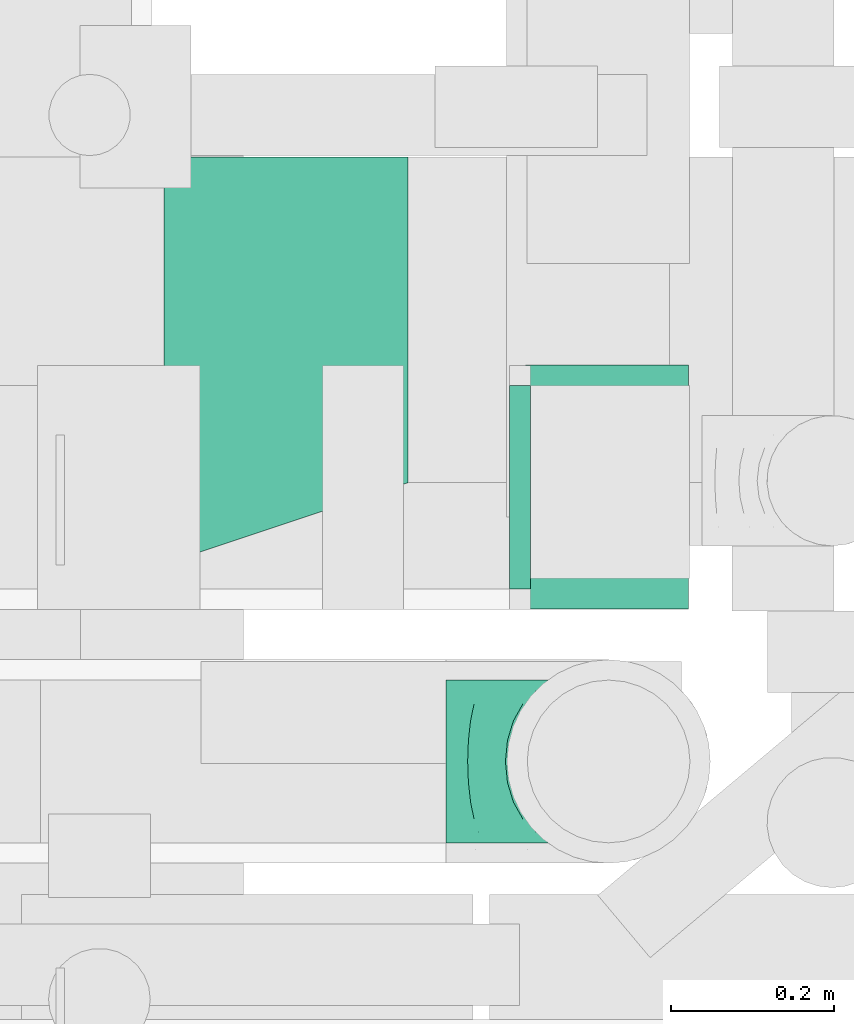
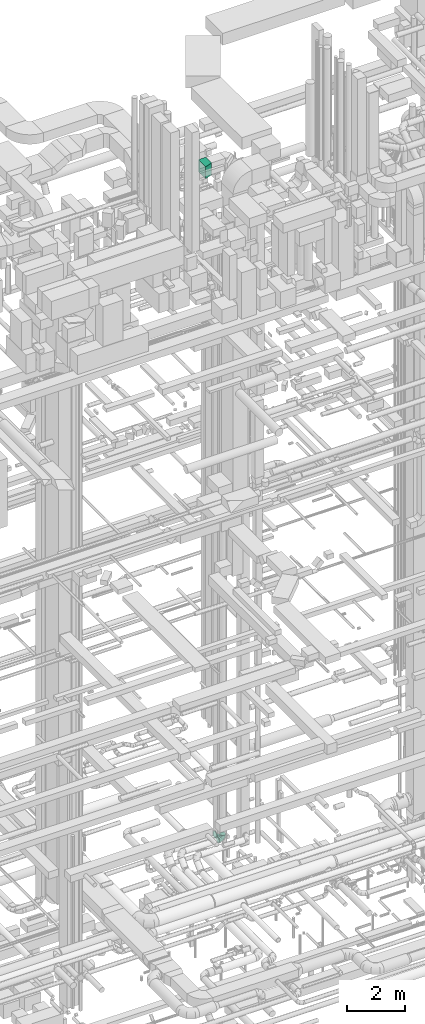
# One storey, part 194 of 337: 4 flow fittings.
"""IFC2X3 building model written with IfcOpenShell, lengths in millimetres."""

import ifcopenshell
import ifcopenshell.guid

model = None  # the IFC model being written
_history = None  # IfcOwnerHistory: only IFC2X3 demands one
_inside = {}  # id of a spatial element -> (the spatial element, [elements in it])
_under = {}  # id of a project, library or spatial element -> (it, [spatial elements below it])
_declared = {}  # id of a project -> (the project, [libraries it declares])
_typed = {}  # id of a type object -> (the type object, [elements of that type])
_made_of = {}  # id of a material, layer set ... -> (it, [elements and type objects made of it])


def new_model(schema):
    """Start an empty IFC model of exactly this schema.

    Asked for "IFC4X3", IfcOpenShell would pick the latest addendum, in which some entities
    have other attributes; the version numbers below select the first issue.
    IFC2X3 requires an IfcOwnerHistory on every rooted entity: one is made here for all.
    """
    global model, _history
    if schema == "IFC4X3":
        model = ifcopenshell.file(schema_version=(4, 3, 0, 0))
    else:
        model = ifcopenshell.file(schema=schema)
    _inside.clear()
    _under.clear()
    _declared.clear()
    _typed.clear()
    _made_of.clear()
    _history = None
    if model.schema == "IFC2X3":
        org = make("IfcOrganization", Name="unknown")
        user = make(
            "IfcPersonAndOrganization",
            ThePerson=make("IfcPerson", FamilyName="unknown"),
            TheOrganization=org,
        )
        app = make(
            "IfcApplication",
            ApplicationDeveloper=org,
            Version="unknown",
            ApplicationFullName="unknown",
            ApplicationIdentifier="unknown",
        )
        _history = make(
            "IfcOwnerHistory",
            OwningUser=user,
            OwningApplication=app,
            ChangeAction="ADDED",
            CreationDate=0,
        )
    return model


def make(cls, **values):
    """One entity of the class cls with the attributes given. An attribute that is None is left unset."""
    return model.create_entity(
        cls, **{name: value for name, value in values.items() if value is not None}
    )


def entity(cls, *values):
    """Any entity or typed value of the class cls, its attributes in the order of the schema. None: left unset."""
    e = model.create_entity(cls)
    for i, value in enumerate(values):
        if value is not None:
            e[i] = value
    return e


def rooted(cls, **values):
    """An entity with a GlobalId (a new one), such as an element, a storey or a relation."""
    return make(cls, GlobalId=ifcopenshell.guid.new(), OwnerHistory=_history, **values)


def si_unit(unit_type, name, prefix=None):
    """IfcSIUnit, for example si_unit("LENGTHUNIT", "METRE", prefix="MILLI")."""
    return make("IfcSIUnit", UnitType=unit_type, Prefix=prefix, Name=name)


def converted_unit(unit_type, name, factor, base, dimensions=None, offset=None):
    """IfcConversionBasedUnit, such as the inch: factor (a typed value) times the base unit."""
    return make(
        "IfcConversionBasedUnit"
        if offset is None
        else "IfcConversionBasedUnitWithOffset",
        ConversionOffset=offset,
        Dimensions=None
        if dimensions is None
        else entity("IfcDimensionalExponents", *dimensions),
        UnitType=unit_type,
        Name=name,
        ConversionFactor=make(
            "IfcMeasureWithUnit", ValueComponent=factor, UnitComponent=base
        ),
    )


def derived_unit(unit_type, elements):
    """IfcDerivedUnit: a product of units, each with its exponent."""
    return make(
        "IfcDerivedUnit",
        Elements=[
            make("IfcDerivedUnitElement", Unit=unit, Exponent=power)
            for unit, power in elements
        ],
        UnitType=unit_type,
    )


def assignment(units):
    """IfcUnitAssignment: the units of a project."""
    return None if units is None else make("IfcUnitAssignment", Units=units)


def point(xyz):
    """IfcCartesianPoint."""
    return None if xyz is None else make("IfcCartesianPoint", Coordinates=xyz)


def direction(xyz):
    """IfcDirection."""
    return None if xyz is None else make("IfcDirection", DirectionRatios=xyz)


def frame(location, z_axis=None, x_axis=None):
    """IfcAxis2Placement3D, a coordinate frame: its origin and axes. An axis left out is left unset."""
    return make(
        "IfcAxis2Placement3D",
        Location=point(location),
        Axis=direction(z_axis),
        RefDirection=direction(x_axis),
    )


def frame_2d(location, x_axis=None):
    """IfcAxis2Placement2D, a coordinate frame in the plane: its origin and x axis."""
    return make(
        "IfcAxis2Placement2D", Location=point(location), RefDirection=direction(x_axis)
    )


def origin():
    """The frame at (0, 0, 0) with its axes left unset."""
    return frame((0.0, 0.0, 0.0))


def origin_2d_with_axis():
    """The frame at (0, 0) in the plane with the x axis (1, 0) written out."""
    return frame_2d((0.0, 0.0), x_axis=(1.0, 0.0))


def place(relative_to, where):
    """IfcLocalPlacement: puts the frame where relative to a parent placement (None: the world)."""
    return make(
        "IfcLocalPlacement", PlacementRelTo=relative_to, RelativePlacement=where
    )


def context(
    kind, dimensions, precision=None, world=None, true_north=None, identifier=None
):
    """IfcGeometricRepresentationContext, for example the 3D "Model" context."""
    return make(
        "IfcGeometricRepresentationContext",
        ContextIdentifier=identifier,
        ContextType=kind,
        CoordinateSpaceDimension=dimensions,
        Precision=precision,
        WorldCoordinateSystem=world,
        TrueNorth=true_north,
    )


def subcontext(parent, identifier, kind, view, scale=None):
    """IfcGeometricRepresentationSubContext, for example "Body" below "Model"."""
    return make(
        "IfcGeometricRepresentationSubContext",
        ContextIdentifier=identifier,
        ContextType=kind,
        ParentContext=parent,
        TargetScale=scale,
        TargetView=view,
    )


def project(units=None, contexts=None):
    """IfcProject with its units and contexts."""
    return rooted(
        "IfcProject",
        Name="project",
        RepresentationContexts=contexts,
        UnitsInContext=assignment(units),
    )


def spatial(cls, under=None, at=None, **own):
    """A site, building, storey or space (cls), placed at a placement, below another one or the project."""
    s = rooted(cls, ObjectPlacement=at, **own)
    if under is not None:
        _under.setdefault(under.id(), (under, []))[1].append(s)
    return s


def polyline(points):
    """IfcPolyline through the points."""
    return make("IfcPolyline", Points=[point(p) for p in points])


def profile(cls, at=None, kind="AREA", **sizes):
    """A parametric profile (cls). Its sizes go by their IFC names, for example OverallWidth=200.0."""
    return make(cls, ProfileType=kind, Position=at, **sizes)


def rectangle(**sizes):
    """IfcRectangleProfileDef."""
    return profile("IfcRectangleProfileDef", **sizes)


def outline(outer, holes=None, kind="AREA"):
    """IfcArbitraryClosedProfileDef: a profile drawn as a closed curve; with holes, ...WithVoids."""
    if holes is None:
        return make("IfcArbitraryClosedProfileDef", ProfileType=kind, OuterCurve=outer)
    return make(
        "IfcArbitraryProfileDefWithVoids",
        ProfileType=kind,
        OuterCurve=outer,
        InnerCurves=holes,
    )


def extrude(swept, where, along, depth):
    """IfcExtrudedAreaSolid: the profile swept, set in the frame where, extruded along a direction by depth."""
    return make(
        "IfcExtrudedAreaSolid",
        SweptArea=swept,
        Position=where,
        ExtrudedDirection=direction(along),
        Depth=depth,
    )


def faces_of(points, faces, orient=None, outer=None):
    """IfcFace entities. A face is a list of loops; a loop is a list of indices into points, from 0.

    orient and outer hold one flag for each loop. By default every Orientation is true, the
    first loop of a face is its IfcFaceOuterBound and the others are IfcFaceBound.
    """
    made = []
    for i, loops in enumerate(faces):
        bounds = []
        for j, loop in enumerate(loops):
            is_outer = j == 0 if outer is None else outer[i][j]
            bounds.append(
                make(
                    "IfcFaceOuterBound" if is_outer else "IfcFaceBound",
                    Bound=make("IfcPolyLoop", Polygon=[points[k] for k in loop]),
                    Orientation=True if orient is None else orient[i][j],
                )
            )
        made.append(make("IfcFace", Bounds=bounds))
    return made


def faceted_brep(points, faces, orient=None, outer=None, voids=None):
    """IfcFacetedBrep: a solid bounded by flat faces; with voids (closed shells), ...WithVoids."""
    shared = [point(p) for p in points]
    hull = make("IfcClosedShell", CfsFaces=faces_of(shared, faces, orient, outer))
    if voids is None:
        return make("IfcFacetedBrep", Outer=hull)
    return make(
        "IfcFacetedBrepWithVoids",
        Outer=hull,
        Voids=[
            make(cls, CfsFaces=faces_of(shared, fs, o, b)) for cls, fs, o, b in voids
        ],
    )


def shape(context_of_items, identifier, shape_type, items):
    """IfcShapeRepresentation: the items that make up one representation, for example the "Body"."""
    return make(
        "IfcShapeRepresentation",
        ContextOfItems=context_of_items,
        RepresentationIdentifier=identifier,
        RepresentationType=shape_type,
        Items=items,
    )


def source(mapping_origin, context_of_items, identifier, shape_type, items):
    """IfcRepresentationMap: a shape defined once, which mapped items show again and again."""
    return make(
        "IfcRepresentationMap",
        MappingOrigin=mapping_origin,
        MappedRepresentation=shape(context_of_items, identifier, shape_type, items),
    )


def transform(
    local_origin,
    x_axis=None,
    y_axis=None,
    z_axis=None,
    scale=None,
    scale2=None,
    scale3=None,
    uniform=True,
):
    """IfcCartesianTransformationOperator3D, or its non-uniform kind. x_axis, y_axis, z_axis: its Axis1, 2, 3."""
    if uniform:
        return make(
            "IfcCartesianTransformationOperator3D",
            Axis1=direction(x_axis),
            Axis2=direction(y_axis),
            LocalOrigin=point(local_origin),
            Scale=scale,
            Axis3=direction(z_axis),
        )
    return make(
        "IfcCartesianTransformationOperator3DnonUniform",
        Axis1=direction(x_axis),
        Axis2=direction(y_axis),
        LocalOrigin=point(local_origin),
        Scale=scale,
        Axis3=direction(z_axis),
        Scale2=scale2,
        Scale3=scale3,
    )


def mapped(mapping_source, mapping_target):
    """IfcMappedItem: shows the shape of a source again, moved by a transform."""
    return make(
        "IfcMappedItem", MappingSource=mapping_source, MappingTarget=mapping_target
    )


def material(Name=None, Category=None):
    """IfcMaterial."""
    return make("IfcMaterial", Name=Name, Category=Category)


def made_of(thing, what):
    """Note that an element or type object is made of a material, layer set ...; save() writes the relation."""
    if what is not None:
        _made_of.setdefault(what.id(), (what, []))[1].append(thing)
    return thing


def type_object(cls, material=None, **own):
    """A type object (cls), such as IfcWallType, which elements share."""
    return made_of(rooted(cls, **own), material)


def type_shapes(of_type, sources):
    """Give a type object the sources (RepresentationMaps) that its elements show as mapped items."""
    of_type.RepresentationMaps = sources


def element(
    cls,
    number,
    at=None,
    inside=None,
    cuts=None,
    type_object=None,
    material=None,
    context=None,
    identifier="Body",
    shape_type=None,
    held_by="IfcProductDefinitionShape",
    body=None,
    shapes=None,
    **own,
):
    """One element of the class cls, such as IfcWall. Its Tag is "e" and its number.

    at: its placement. inside: the storey or other place that contains it. cuts: it is an
    opening in that element (IfcRelVoidsElement). A single representation is given by context,
    identifier, shape_type and body (its items); several are given by shapes. held_by: the class
    of the entity that holds the representations. save() writes the other relations.
    """
    e = rooted(cls, Tag="e%d" % number, ObjectPlacement=at, **own)
    if body is not None:
        shapes = [shape(context, identifier, shape_type, body)]
    if shapes is not None:
        e.Representation = make(held_by, Representations=shapes)
    if inside is not None:
        _inside.setdefault(inside.id(), (inside, []))[1].append(e)
    if cuts is not None:
        rooted(
            "IfcRelVoidsElement", RelatingBuildingElement=cuts, RelatedOpeningElement=e
        )
    if type_object is not None:
        _typed.setdefault(type_object.id(), (type_object, []))[1].append(e)
    return made_of(e, material)


def aggregate(whole, parts):
    """IfcRelAggregates: a whole, such as a stair, and the parts it consists of."""
    return rooted("IfcRelAggregates", RelatingObject=whole, RelatedObjects=parts)


def save(model, path):
    """Write the relations noted so far, then the file.

    IfcRelAggregates (storeys below a building ...), IfcRelContainedInSpatialStructure (elements
    in a storey), IfcRelDefinesByType, IfcRelAssociatesMaterial and IfcRelDeclares: one each for
    every whole, place, type object, material and project.
    """
    for whole, parts in _under.values():
        aggregate(whole, parts)
    for where, things in _inside.values():
        rooted(
            "IfcRelContainedInSpatialStructure",
            RelatedElements=things,
            RelatingStructure=where,
        )
    for kind, things in _typed.values():
        rooted("IfcRelDefinesByType", RelatedObjects=things, RelatingType=kind)
    for what, things in _made_of.values():
        rooted("IfcRelAssociatesMaterial", RelatedObjects=things, RelatingMaterial=what)
    for by, libraries in _declared.values():
        rooted("IfcRelDeclares", RelatingContext=by, RelatedDefinitions=libraries)
    model.write(path)


model = new_model("IFC2X3")

# Units and contexts
model_context = context("Model", 3, precision=0.01, world=origin(), true_north=direction((6.12303176911189e-17, 1.0)))
body_context = subcontext(model_context, "Body", "Model", "MODEL_VIEW")
ifc_project = project(units=[si_unit("LENGTHUNIT", "METRE", prefix="MILLI"), si_unit("AREAUNIT", "SQUARE_METRE"), si_unit("VOLUMEUNIT", "CUBIC_METRE"), converted_unit("PLANEANGLEUNIT", "DEGREE", entity("IfcRatioMeasure", 0.0174532925199433), si_unit("PLANEANGLEUNIT", "RADIAN"), dimensions=[0, 0, 0, 0, 0, 0, 0]), si_unit("MASSUNIT", "GRAM", prefix="KILO"), derived_unit("MASSDENSITYUNIT", [(si_unit("MASSUNIT", "GRAM", prefix="KILO"), 1), (si_unit("LENGTHUNIT", "METRE"), -3)]), derived_unit("MOMENTOFINERTIAUNIT", [(si_unit("LENGTHUNIT", "METRE"), 4)]), si_unit("TIMEUNIT", "SECOND"), si_unit("FREQUENCYUNIT", "HERTZ"), si_unit("THERMODYNAMICTEMPERATUREUNIT", "DEGREE_CELSIUS"), derived_unit("THERMALTRANSMITTANCEUNIT", [(si_unit("MASSUNIT", "GRAM", prefix="KILO"), 1), (si_unit("THERMODYNAMICTEMPERATUREUNIT", "KELVIN"), -1), (si_unit("TIMEUNIT", "SECOND"), -3)]), derived_unit("VOLUMETRICFLOWRATEUNIT", [(si_unit("LENGTHUNIT", "METRE"), 3), (si_unit("TIMEUNIT", "SECOND"), -1)]), derived_unit("MASSFLOWRATEUNIT", [(si_unit("MASSUNIT", "GRAM", prefix="KILO"), 1), (si_unit("TIMEUNIT", "SECOND"), -1)]), derived_unit("ROTATIONALFREQUENCYUNIT", [(si_unit("TIMEUNIT", "SECOND"), -1)]), si_unit("ELECTRICCURRENTUNIT", "AMPERE"), si_unit("ELECTRICVOLTAGEUNIT", "VOLT"), si_unit("POWERUNIT", "WATT"), si_unit("FORCEUNIT", "NEWTON", prefix="KILO"), si_unit("ILLUMINANCEUNIT", "LUX"), si_unit("LUMINOUSFLUXUNIT", "LUMEN"), si_unit("LUMINOUSINTENSITYUNIT", "CANDELA"), derived_unit("USERDEFINED", [(si_unit("MASSUNIT", "GRAM", prefix="KILO"), -1), (si_unit("LENGTHUNIT", "METRE"), -2), (si_unit("TIMEUNIT", "SECOND"), 3), (si_unit("LUMINOUSFLUXUNIT", "LUMEN"), 1)]), derived_unit("LINEARVELOCITYUNIT", [(si_unit("LENGTHUNIT", "METRE"), 1), (si_unit("TIMEUNIT", "SECOND"), -1)]), si_unit("PRESSUREUNIT", "PASCAL"), derived_unit("USERDEFINED", [(si_unit("LENGTHUNIT", "METRE"), -2), (si_unit("MASSUNIT", "GRAM", prefix="KILO"), 1), (si_unit("TIMEUNIT", "SECOND"), -2)]), derived_unit("LINEARFORCEUNIT", [(si_unit("MASSUNIT", "GRAM", prefix="KILO"), 1), (si_unit("LENGTHUNIT", "METRE"), 1), (si_unit("TIMEUNIT", "SECOND"), -2), (si_unit("LENGTHUNIT", "METRE"), -1)]), derived_unit("PLANARFORCEUNIT", [(si_unit("MASSUNIT", "GRAM", prefix="KILO"), 1), (si_unit("LENGTHUNIT", "METRE"), 1), (si_unit("TIMEUNIT", "SECOND"), -2), (si_unit("LENGTHUNIT", "METRE"), -2)])], contexts=[model_context])

# Site, building, storey
site_placement = place(None, origin())
site = spatial("IfcSite", under=ifc_project, at=site_placement, CompositionType="ELEMENT")
building_placement = place(site_placement, origin())
building = spatial("IfcBuilding", under=site, at=building_placement, CompositionType="ELEMENT")
storey_placement = place(building_placement, origin())
storey = spatial("IfcBuildingStorey", under=building, at=storey_placement, CompositionType="ELEMENT", Elevation=0.0)

# Flow fittings
ifc_material = material()
duct_fitting_type_1 = type_object("IfcDuctFittingType", PredefinedType="NOTDEFINED", material=ifc_material)
shared_shape_1 = source(origin(), body_context, "Body", "SweptSolid", [
    extrude(rectangle(XDim=24.9999999999999, YDim=200.0, at=origin_2d_with_axis()), frame((12.5, 0.0, -150.0)), (0.0, 0.0, 1.0), 300.0),
])
type_shapes(duct_fitting_type_1, [shared_shape_1])
flow_fitting_1_placement = place(storey_placement, frame((51789.86, 12586.32, 3324.93), z_axis=(0.0, -1.0, 0.0), x_axis=(0.0, 0.0, -1.0)))
element("IfcFlowFitting", 1, at=flow_fitting_1_placement, inside=storey, type_object=duct_fitting_type_1, material=ifc_material, context=body_context, shape_type="MappedRepresentation", body=[
    mapped(shared_shape_1, transform((0.0, 0.0, 0.0), scale=1.0)),
])
duct_fitting_type_2 = type_object("IfcDuctFittingType", PredefinedType="NOTDEFINED", material=ifc_material)
shared_shape_2 = source(origin(), body_context, "Body", "SweptSolid", [
    extrude(outline(polyline([(-229.27, -213.45), (86.96, -213.45), (213.45, 166.02), (-71.15, 260.89), (-229.27, -213.45)])), frame((150.0, 25.0, -250.0), z_axis=(0.0, 0.0, 1.0), x_axis=(0.948683298050514, 0.316227766016836, 0.0)), (0.0, 0.0, 1.0), 500.0),
])
type_shapes(duct_fitting_type_2, [shared_shape_2])
flow_fitting_2_placement = place(storey_placement, frame((51245.21, 12741.6, 31470.0)))
element("IfcFlowFitting", 2, at=flow_fitting_2_placement, inside=storey, type_object=duct_fitting_type_2, material=ifc_material, context=body_context, shape_type="MappedRepresentation", body=[
    mapped(shared_shape_2, transform((0.0, 0.0, 0.0), scale=1.0)),
])
duct_fitting_type_3 = type_object("IfcDuctFittingType", PredefinedType="NOTDEFINED", material=ifc_material)
shared_shape_3 = source(origin(), body_context, "Body", "Brep", [
    faceted_brep([(20.0, 32.35, -120.74), (20.0, 62.5, -108.25), (20.0, 88.39, -88.39), (20.0, 108.25, -62.5), (20.0, 120.74, -32.35), (20.0, 125.0, 0.0), (20.0, 120.74, 32.35), (20.0, 108.25, 62.5), (20.0, 88.39, 88.39), (20.0, 62.5, 108.25), (20.0, 32.35, 120.74), (20.0, 0.0, 125.0), (20.0, -32.35, 120.74), (20.0, -62.5, 108.25), (20.0, -88.39, 88.39), (20.0, -108.25, 62.5), (20.0, -120.74, 32.35), (20.0, -125.0, 0.0), (20.0, -120.74, -32.35), (20.0, -108.25, -62.5), (20.0, -88.39, -88.39), (20.0, -62.5, -108.25), (20.0, -32.35, -120.74), (20.0, 0.0, -125.0), (0.0, 0.0, 125.0), (0.0, 32.35, 120.74), (-6.1, 32.35, 120.74), (-6.1, 0.0, 125.0), (0.0, 62.5, 108.25), (-6.1, 62.5, 108.25), (0.0, 88.39, 88.39), (-6.1, 88.39, 88.39), (0.0, 108.25, 62.5), (0.0, 120.74, 32.35), (-6.1, 120.74, 32.35), (-6.1, 108.25, 62.5), (0.0, 125.0, 0.0), (-6.1, 125.0, 0.0), (0.0, 120.74, -32.35), (-6.1, 120.74, -32.35), (0.0, 108.25, -62.5), (-6.1, 108.25, -62.5), (0.0, 88.39, -88.39), (-6.1, 88.39, -88.39), (0.0, 62.5, -108.25), (0.0, 32.35, -120.74), (-6.1, 32.35, -120.74), (-6.1, 62.5, -108.25), (0.0, 0.0, -125.0), (-6.1, 0.0, -125.0), (0.0, -32.35, -120.74), (-6.1, -32.35, -120.74), (0.0, -62.5, -108.25), (-6.1, -62.5, -108.25), (0.0, -88.39, -88.39), (-6.1, -88.39, -88.39), (0.0, -108.25, -62.5), (0.0, -120.74, -32.35), (-6.1, -120.74, -32.35), (-6.1, -108.25, -62.5), (0.0, -125.0, 0.0), (-6.1, -125.0, 0.0), (0.0, -120.74, 32.35), (-6.1, -120.74, 32.35), (0.0, -108.25, 62.5), (-6.1, -108.25, 62.5), (0.0, -88.39, 88.39), (-6.1, -88.39, 88.39), (0.0, -62.5, 108.25), (0.0, -32.35, 120.74), (-6.1, -32.35, 120.74), (-6.1, -62.5, 108.25)], [[[0, 1, 2, 3, 4, 5, 6, 7, 8, 9, 10, 11, 12, 13, 14, 15, 16, 17, 18, 19, 20, 21, 22, 23]], [[24, 11, 10, 25, 26, 27]], [[25, 10, 9, 28, 29, 26]], [[28, 9, 8, 30, 31, 29]], [[32, 7, 6, 33, 34, 35]], [[33, 6, 5, 36, 37, 34]], [[30, 8, 7, 32, 35, 31]], [[36, 5, 4, 38, 39, 37]], [[38, 4, 3, 40, 41, 39]], [[40, 3, 2, 42, 43, 41]], [[44, 1, 0, 45, 46, 47]], [[45, 0, 23, 48, 49, 46]], [[42, 2, 1, 44, 47, 43]], [[48, 23, 22, 50, 51, 49]], [[50, 22, 21, 52, 53, 51]], [[52, 21, 20, 54, 55, 53]], [[56, 19, 18, 57, 58, 59]], [[57, 18, 17, 60, 61, 58]], [[54, 20, 19, 56, 59, 55]], [[60, 17, 16, 62, 63, 61]], [[62, 16, 15, 64, 65, 63]], [[64, 15, 14, 66, 67, 65]], [[68, 13, 12, 69, 70, 71]], [[69, 12, 11, 24, 27, 70]], [[66, 14, 13, 68, 71, 67]], [[49, 51, 53, 55, 59, 58, 61, 63, 65, 67, 71, 70, 27, 26, 29, 31, 35, 34, 37, 39, 41, 43, 47, 46]]]),
])
type_shapes(duct_fitting_type_3, [shared_shape_3])
flow_fitting_3_placement = place(storey_placement, frame((51689.86, 12585.76, 3450.0), z_axis=(0.0, 1.0, 0.0), x_axis=(-1.0, 0.0, 0.0)))
element("IfcFlowFitting", 3, at=flow_fitting_3_placement, inside=storey, type_object=duct_fitting_type_3, material=ifc_material, context=body_context, shape_type="MappedRepresentation", body=[
    mapped(shared_shape_3, transform((0.0, 0.0, 0.0), scale=1.0)),
])
duct_fitting_type_4 = type_object("IfcDuctFittingType", PredefinedType="NOTDEFINED", material=ifc_material)
shared_shape_4 = source(origin(), body_context, "Body", "Brep", [
    faceted_brep([(-200.0, 0.0, -100.0), (-200.0, -25.88, -96.59), (-200.0, -50.0, -86.6), (-200.0, -70.71, -70.71), (-200.0, -86.6, -50.0), (-200.0, -96.59, -25.88), (-200.0, -100.0, 0.0), (-200.0, -96.59, 25.88), (-200.0, -86.6, 50.0), (-200.0, -70.71, 70.71), (-200.0, -50.0, 86.6), (-200.0, -25.88, 96.59), (-200.0, 0.0, 100.0), (-200.0, 25.88, 96.59), (-200.0, 50.0, 86.6), (-200.0, 70.71, 70.71), (-200.0, 86.6, 50.0), (-200.0, 96.59, 25.88), (-200.0, 100.0, 0.0), (-200.0, 96.59, -25.88), (-200.0, 86.6, -50.0), (-200.0, 70.71, -70.71), (-200.0, 50.0, -86.6), (-200.0, 25.88, -96.59), (-153.35, 25.88, 96.59), (-159.81, 50.0, 86.6), (-146.41, 0.0, 100.0), (-165.36, 70.71, 70.71), (-172.29, 96.59, 25.88), (-173.21, 100.0, 0.0), (-169.62, 86.6, 50.0), (-169.62, 86.6, -50.0), (-165.36, 70.71, -70.71), (-172.29, 96.59, -25.88), (-153.35, 25.88, -96.59), (-146.41, 0.0, -100.0), (-159.81, 50.0, -86.6), (-139.48, -25.88, -96.59), (-133.01, -50.0, -86.6), (-127.46, -70.71, -70.71), (-123.21, -86.6, -50.0), (-120.53, -96.59, -25.88), (-119.62, -100.0, 0.0), (-120.53, -96.59, 25.88), (-123.21, -86.6, 50.0), (-127.46, -70.71, 70.71), (-133.01, -50.0, 86.6), (-139.48, -25.88, 96.59), (-72.54, 72.54, 96.59), (-90.19, 90.19, 86.6), (-53.59, 53.59, 100.0), (-105.35, 105.35, 70.71), (-116.99, 116.99, 50.0), (-124.3, 124.3, 25.88), (-126.79, 126.79, 0.0), (-124.3, 124.3, -25.88), (-116.99, 116.99, -50.0), (-105.35, 105.35, -70.71), (-72.54, 72.54, -96.59), (-53.59, 53.59, -100.0), (-90.19, 90.19, -86.6), (-34.64, 34.64, -96.59), (-16.99, 16.99, -86.6), (-1.83, 1.83, -70.71), (9.81, -9.81, -50.0), (17.12, -17.12, -25.88), (19.62, -19.62, 0.0), (17.12, -17.12, 25.88), (9.81, -9.81, 50.0), (-1.83, 1.83, 70.71), (-16.99, 16.99, 86.6), (-34.64, 34.64, 96.59), (-25.88, 153.35, 96.59), (-50.0, 159.81, 86.6), (0.0, 146.41, 100.0), (-70.71, 165.36, 70.71), (-86.6, 169.62, 50.0), (-96.59, 172.29, 25.88), (-100.0, 173.21, 0.0), (-96.59, 172.29, -25.88), (-86.6, 169.62, -50.0), (-70.71, 165.36, -70.71), (-25.88, 153.35, -96.59), (0.0, 146.41, -100.0), (-50.0, 159.81, -86.6), (25.88, 139.48, -96.59), (50.0, 133.01, -86.6), (70.71, 127.46, -70.71), (86.6, 123.21, -50.0), (96.59, 120.53, -25.88), (100.0, 119.62, 0.0), (96.59, 120.53, 25.88), (86.6, 123.21, 50.0), (70.71, 127.46, 70.71), (50.0, 133.01, 86.6), (25.88, 139.48, 96.59), (-25.88, 200.0, -96.59), (-50.0, 200.0, -86.6), (-70.71, 200.0, -70.71), (-86.6, 200.0, -50.0), (-96.59, 200.0, -25.88), (-100.0, 200.0, 0.0), (-96.59, 200.0, 25.88), (-86.6, 200.0, 50.0), (-70.71, 200.0, 70.71), (-50.0, 200.0, 86.6), (-25.88, 200.0, 96.59), (0.0, 200.0, 100.0), (25.88, 200.0, 96.59), (50.0, 200.0, 86.6), (70.71, 200.0, 70.71), (86.6, 200.0, 50.0), (96.59, 200.0, 25.88), (100.0, 200.0, 0.0), (96.59, 200.0, -25.88), (86.6, 200.0, -50.0), (70.71, 200.0, -70.71), (50.0, 200.0, -86.6), (25.88, 200.0, -96.59), (0.0, 200.0, -100.0)], [[[0, 1, 2, 3, 4, 5, 6, 7, 8, 9, 10, 11, 12, 13, 14, 15, 16, 17, 18, 19, 20, 21, 22, 23]], [[24, 25, 14, 13]], [[26, 24, 13, 12]], [[14, 25, 27, 15]], [[28, 29, 18, 17]], [[30, 28, 17, 16]], [[15, 27, 30, 16]], [[20, 31, 32, 21]], [[33, 31, 20, 19]], [[18, 29, 33, 19]], [[34, 35, 0, 23]], [[36, 34, 23, 22]], [[32, 36, 22, 21]], [[1, 0, 35, 37]], [[2, 1, 37, 38]], [[38, 39, 3, 2]], [[5, 4, 40, 41]], [[6, 5, 41, 42]], [[39, 40, 4, 3]], [[6, 42, 43, 7]], [[7, 43, 44, 8]], [[8, 44, 45, 9]], [[9, 45, 46, 10]], [[10, 46, 47, 11]], [[26, 12, 11, 47]], [[48, 49, 25, 24]], [[50, 48, 24, 26]], [[27, 25, 49, 51]], [[52, 53, 28, 30]], [[51, 52, 30, 27]], [[29, 28, 53, 54]], [[55, 56, 31, 33]], [[54, 55, 33, 29]], [[32, 31, 56, 57]], [[58, 59, 35, 34]], [[60, 58, 34, 36]], [[57, 60, 36, 32]], [[37, 35, 59, 61]], [[38, 37, 61, 62]], [[39, 38, 62, 63]], [[41, 40, 64, 65]], [[42, 41, 65, 66]], [[63, 64, 40, 39]], [[43, 42, 66, 67]], [[44, 43, 67, 68]], [[68, 69, 45, 44]], [[46, 45, 69, 70]], [[47, 46, 70, 71]], [[26, 47, 71, 50]], [[72, 73, 49, 48]], [[74, 72, 48, 50]], [[51, 49, 73, 75]], [[76, 77, 53, 52]], [[75, 76, 52, 51]], [[54, 53, 77, 78]], [[79, 80, 56, 55]], [[78, 79, 55, 54]], [[57, 56, 80, 81]], [[82, 83, 59, 58]], [[84, 82, 58, 60]], [[81, 84, 60, 57]], [[61, 59, 83, 85]], [[62, 61, 85, 86]], [[63, 62, 86, 87]], [[65, 64, 88, 89]], [[66, 65, 89, 90]], [[87, 88, 64, 63]], [[67, 66, 90, 91]], [[68, 67, 91, 92]], [[92, 93, 69, 68]], [[70, 69, 93, 94]], [[71, 70, 94, 95]], [[50, 71, 95, 74]], [[96, 97, 98, 99, 100, 101, 102, 103, 104, 105, 106, 107, 108, 109, 110, 111, 112, 113, 114, 115, 116, 117, 118, 119]], [[72, 74, 107, 106]], [[73, 72, 106, 105]], [[75, 73, 105, 104]], [[102, 101, 78, 77]], [[103, 102, 77, 76]], [[75, 104, 103, 76]], [[78, 101, 100, 79]], [[79, 100, 99, 80]], [[80, 99, 98, 81]], [[84, 97, 96, 82]], [[82, 96, 119, 83]], [[84, 81, 98, 97]], [[118, 117, 86, 85]], [[119, 118, 85, 83]], [[116, 87, 86, 117]], [[88, 115, 114, 89]], [[89, 114, 113, 90]], [[115, 88, 87, 116]], [[91, 90, 113, 112]], [[92, 91, 112, 111]], [[111, 110, 93, 92]], [[95, 94, 109, 108]], [[74, 95, 108, 107]], [[110, 109, 94, 93]]]),
])
type_shapes(duct_fitting_type_4, [shared_shape_4])
flow_fitting_4_placement = place(storey_placement, frame((51791.72, 12249.04, 3450.0), z_axis=(0.0, -1.0, 0.0), x_axis=(1.0, 0.0, 0.0)))
element("IfcFlowFitting", 4, at=flow_fitting_4_placement, inside=storey, type_object=duct_fitting_type_4, material=ifc_material, context=body_context, shape_type="MappedRepresentation", body=[
    mapped(shared_shape_4, transform((0.0, 0.0, 0.0), scale=1.0)),
])

save(model, "model.ifc")
